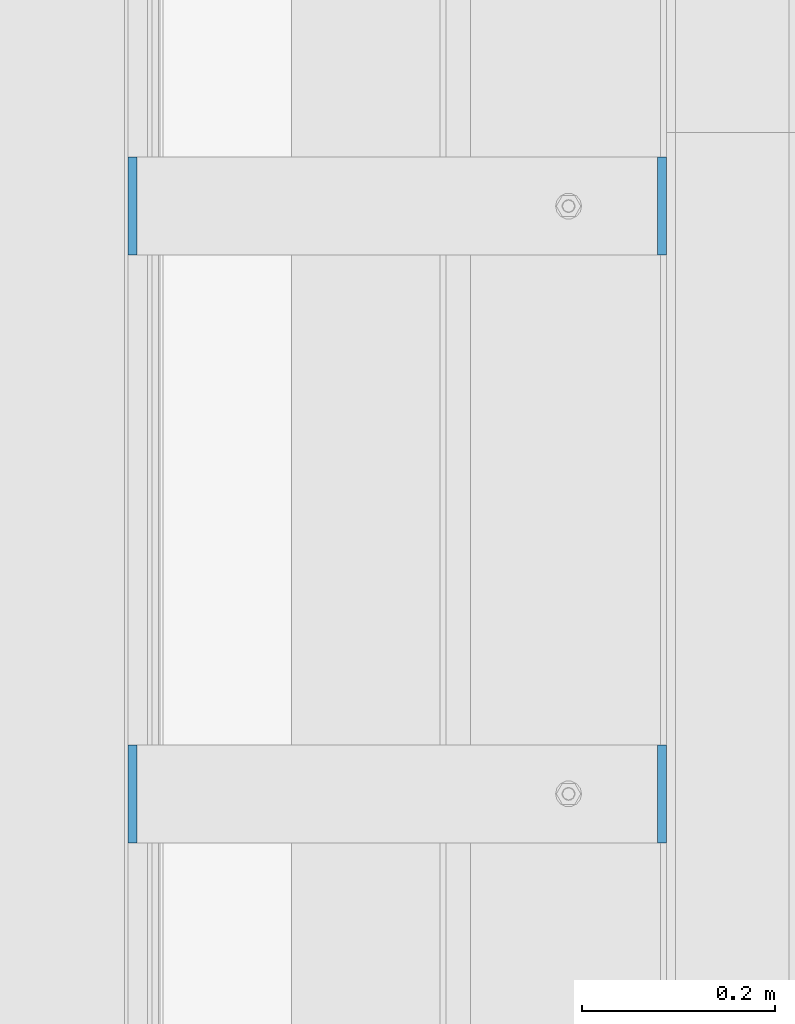
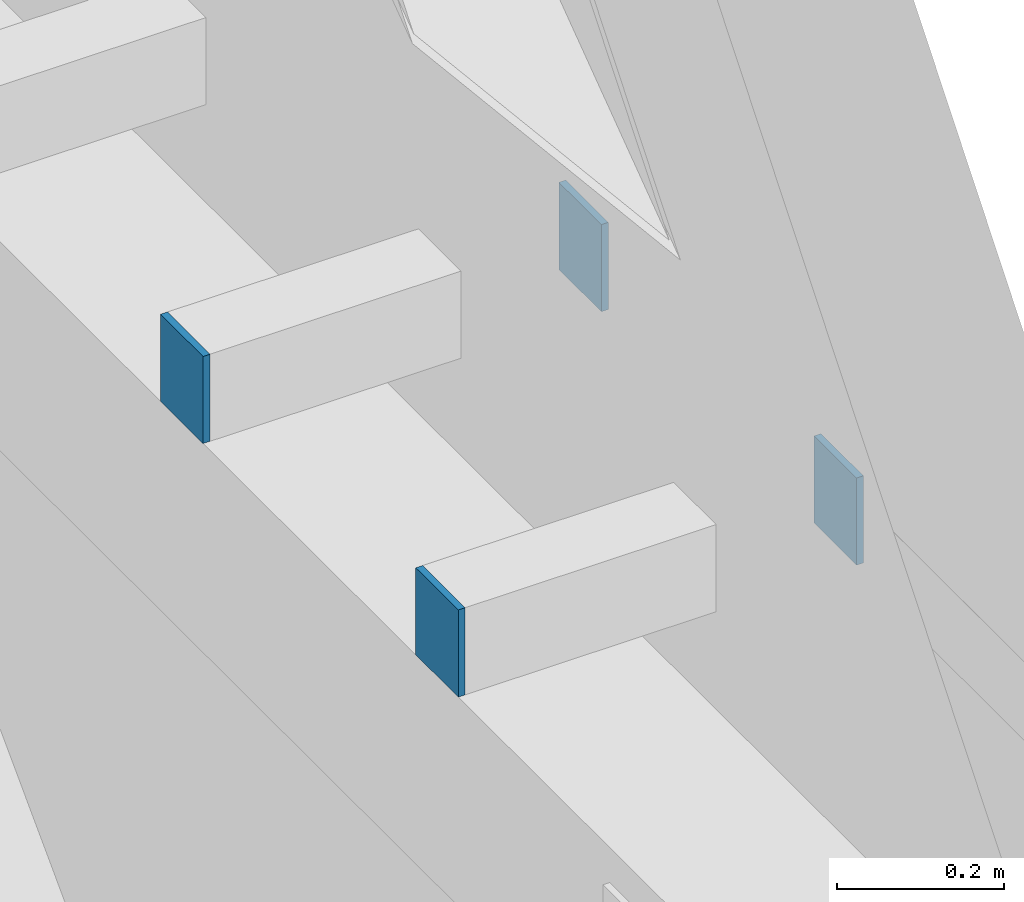
# One storey, part 410 of 1179: 4 columns, 2 elements without a shape of their own.
"""IFC2X3 building model written with IfcOpenShell, lengths in millimetres."""

from ifc_helpers import new_model, si_unit, frame, origin_with_axes, place, context, subcontext, project, spatial, faceted_brep, material, type_object, element, aggregate, save


model = new_model("IFC2X3")

# Units and contexts
model_context = context("Model", 3, precision=1e-05, world=origin_with_axes())
body_context = subcontext(model_context, "Body", "Model", "MODEL_VIEW")
ifc_project = project(units=[si_unit("LENGTHUNIT", "METRE", prefix="MILLI"), si_unit("AREAUNIT", "SQUARE_METRE"), si_unit("VOLUMEUNIT", "CUBIC_METRE"), si_unit("MASSUNIT", "GRAM", prefix="KILO"), si_unit("TIMEUNIT", "SECOND"), si_unit("PLANEANGLEUNIT", "RADIAN"), si_unit("SOLIDANGLEUNIT", "STERADIAN"), si_unit("THERMODYNAMICTEMPERATUREUNIT", "DEGREE_CELSIUS"), si_unit("LUMINOUSINTENSITYUNIT", "LUMEN")], contexts=[model_context])

# Site, building, storey
site_placement = place(None, origin_with_axes())
site = spatial("IfcSite", under=ifc_project, at=site_placement, CompositionType="ELEMENT")
building_placement = place(site_placement, origin_with_axes())
building = spatial("IfcBuilding", under=site, at=building_placement, Name="Undefined", CompositionType="ELEMENT")
storey_placement = place(building_placement, origin_with_axes())
storey = spatial("IfcBuildingStorey", under=building, at=storey_placement, Name="Undefined", CompositionType="ELEMENT", Elevation=0.0)

# Assembly, columns
assembly_1_placement = place(storey_placement, origin_with_axes())
assembly_1 = element("IfcElementAssembly", 1, at=assembly_1_placement, inside=storey, Name="BEAM", AssemblyPlace="NOTDEFINED", PredefinedType="RIGID_FRAME")
ifc_material = material(Name="STEEL/A36")
column_type = type_object("IfcColumnType", PredefinedType="NOTDEFINED")
column_1_placement = place(assembly_1_placement, frame((24734.8375, 13525.5, 8013.69999998781), z_axis=(0.0, 1.0, 0.0), x_axis=(0.0, 0.0, 1.0)))
column_1 = element("IfcColumn", 2, at=column_1_placement, type_object=column_type, material=ifc_material, Name="PLATE", context=body_context, shape_type="Brep", body=[
    faceted_brep([(0.0, 4.76249999999982, -50.7999999999993), (0.0, 4.76249999999982, 50.7999999999993), (127.000000000371, 4.76249999928405, 50.8000000000002), (127.000000000371, 4.76249999928405, -50.8000000000002), (0.0, -4.76249999999982, 50.7999999999993), (127.0, -4.76250000000073, 50.7999999999993), (0.0, -4.76249999999982, -50.7999999999993), (127.0, -4.76250000000073, -50.7999999999993)], [[[0, 1, 2, 3]], [[1, 4, 5, 2]], [[4, 6, 7, 5]], [[6, 0, 3, 7]], [[5, 7, 3, 2]], [[6, 4, 1, 0]]]),
])
column_2_placement = place(assembly_1_placement, frame((24185.5625, 13525.5, 8013.69999998781), z_axis=(0.0, -1.0, 0.0), x_axis=(0.0, 0.0, 1.0)))
column_2 = element("IfcColumn", 3, at=column_2_placement, type_object=column_type, material=ifc_material, Name="PLATE", context=body_context, shape_type="Brep", body=[
    faceted_brep([(0.0, 4.76249999999982, -50.7999999999993), (0.0, 4.76249999999982, 50.7999999999993), (127.000000000371, 4.76249999928405, 50.8000000000002), (127.000000000371, 4.76249999928405, -50.8000000000002), (0.0, -4.76249999999982, 50.7999999999993), (127.0, -4.76250000000073, 50.7999999999993), (0.0, -4.76249999999982, -50.7999999999993), (127.0, -4.76250000000073, -50.7999999999993)], [[[0, 1, 2, 3]], [[1, 4, 5, 2]], [[4, 6, 7, 5]], [[6, 0, 3, 7]], [[5, 7, 3, 2]], [[6, 4, 1, 0]]]),
])
aggregate(assembly_1, [column_1, column_2])

assembly_2_placement = place(storey_placement, origin_with_axes())
assembly_2 = element("IfcElementAssembly", 4, at=assembly_2_placement, inside=storey, Name="BEAM", AssemblyPlace="NOTDEFINED", PredefinedType="RIGID_FRAME")
column_3_placement = place(assembly_2_placement, frame((24734.8375, 12915.9, 8013.69999998781), z_axis=(0.0, 1.0, 0.0), x_axis=(0.0, 0.0, 1.0)))
column_3 = element("IfcColumn", 5, at=column_3_placement, type_object=column_type, material=ifc_material, Name="PLATE", context=body_context, shape_type="Brep", body=[
    faceted_brep([(0.0, 4.76249999999982, -50.7999999999993), (0.0, 4.76249999999982, 50.7999999999993), (127.000000000371, 4.76249999928405, 50.8000000000002), (127.000000000371, 4.76249999928405, -50.8000000000002), (0.0, -4.76249999999982, 50.7999999999993), (127.0, -4.76250000000073, 50.7999999999993), (0.0, -4.76249999999982, -50.7999999999993), (127.0, -4.76250000000073, -50.7999999999993)], [[[0, 1, 2, 3]], [[1, 4, 5, 2]], [[4, 6, 7, 5]], [[6, 0, 3, 7]], [[5, 7, 3, 2]], [[6, 4, 1, 0]]]),
])
column_4_placement = place(assembly_2_placement, frame((24185.5625, 12915.9, 8013.69999998781), z_axis=(0.0, -1.0, 0.0), x_axis=(0.0, 0.0, 1.0)))
column_4 = element("IfcColumn", 6, at=column_4_placement, type_object=column_type, material=ifc_material, Name="PLATE", context=body_context, shape_type="Brep", body=[
    faceted_brep([(0.0, 4.76249999999982, -50.7999999999993), (0.0, 4.76249999999982, 50.7999999999993), (127.000000000371, 4.76249999928405, 50.8000000000002), (127.000000000371, 4.76249999928405, -50.8000000000002), (0.0, -4.76249999999982, 50.7999999999993), (127.0, -4.76250000000073, 50.7999999999993), (0.0, -4.76249999999982, -50.7999999999993), (127.0, -4.76250000000073, -50.7999999999993)], [[[0, 1, 2, 3]], [[1, 4, 5, 2]], [[4, 6, 7, 5]], [[6, 0, 3, 7]], [[5, 7, 3, 2]], [[6, 4, 1, 0]]]),
])
aggregate(assembly_2, [column_3, column_4])

save(model, "model.ifc")
